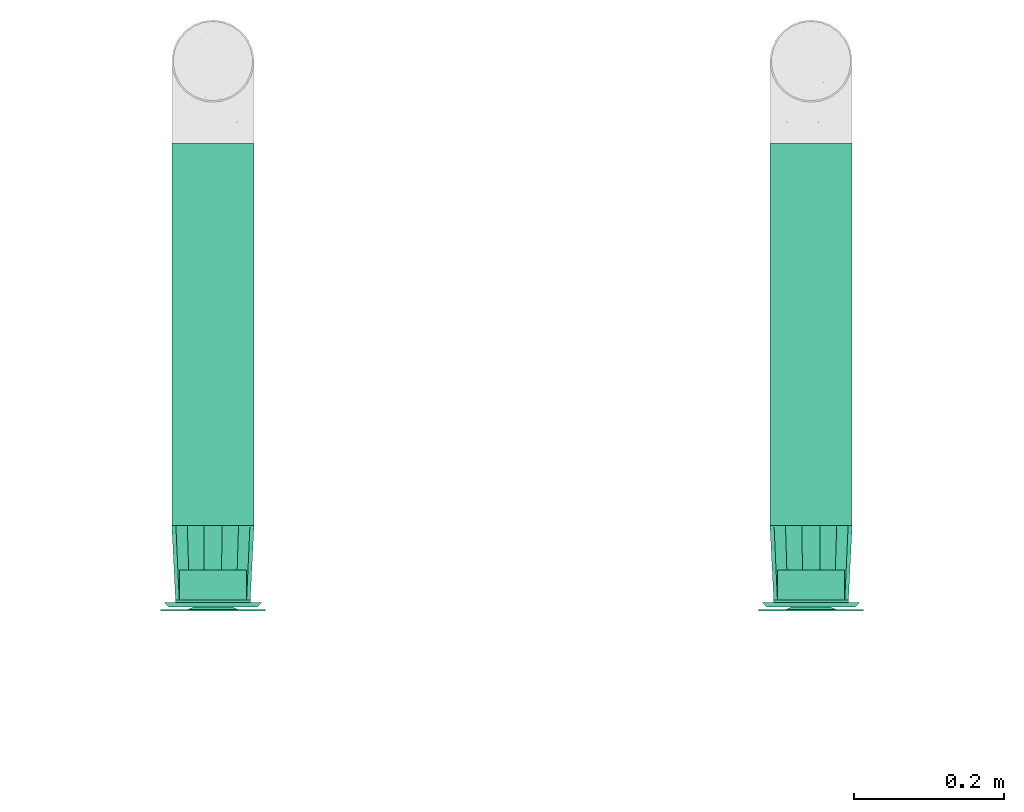
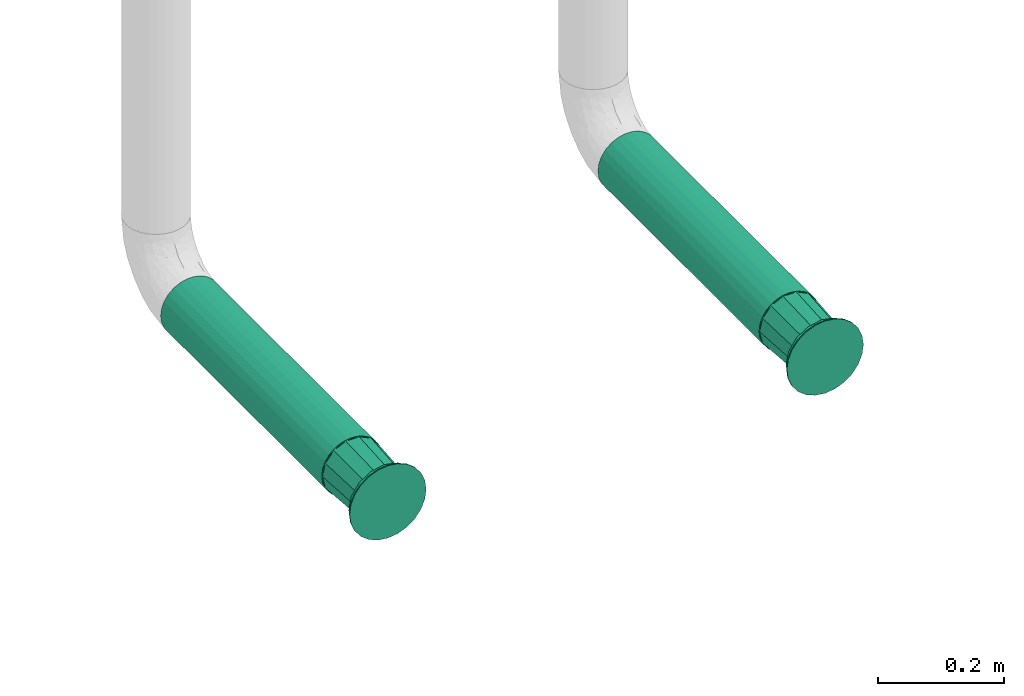
# One storey, part 54 of 115: 2 flow fittings, 2 flow segments, 2 flow terminals.
"""IFC2X3 building model written with IfcOpenShell, lengths in millimetres."""

from ifc_helpers import new_model, entity, si_unit, converted_unit, derived_unit, direction, frame, origin_with_axes, origin_2d_with_axis, place, context, subcontext, project, spatial, hollow_circle, extrude, open_shell, surface_model, source, transform, mapped, material, layer, layer_set, layer_usage, type_object, element, save


model = new_model("IFC2X3")

# Units and contexts
model_context = context("Model", 3, precision=1e-05, world=origin_with_axes(), true_north=direction((0.0, 1.0)))
body_context = subcontext(model_context, "Body", "Model", "MODEL_VIEW")
ifc_project = project(units=[si_unit("AREAUNIT", "SQUARE_METRE"), si_unit("VOLUMEUNIT", "CUBIC_METRE", prefix="DECI"), si_unit("TIMEUNIT", "SECOND"), si_unit("THERMODYNAMICTEMPERATUREUNIT", "DEGREE_CELSIUS"), si_unit("PRESSUREUNIT", "PASCAL"), si_unit("MASSUNIT", "GRAM", prefix="KILO"), si_unit("LENGTHUNIT", "METRE", prefix="MILLI"), si_unit("POWERUNIT", "WATT"), si_unit("ELECTRICCURRENTUNIT", "AMPERE"), si_unit("ELECTRICVOLTAGEUNIT", "VOLT"), derived_unit("VOLUMETRICFLOWRATEUNIT", [(si_unit("VOLUMEUNIT", "CUBIC_METRE", prefix="DECI"), 1), (si_unit("TIMEUNIT", "SECOND"), -1)]), derived_unit("LINEARVELOCITYUNIT", [(si_unit("LENGTHUNIT", "METRE"), 1), (si_unit("TIMEUNIT", "SECOND"), -1)]), derived_unit("MASSDENSITYUNIT", [(si_unit("MASSUNIT", "GRAM", prefix="KILO"), 1), (si_unit("VOLUMEUNIT", "CUBIC_METRE"), -1)]), converted_unit("PLANEANGLEUNIT", "DEGREE", entity("IfcRatioMeasure", 0.01745), si_unit("PLANEANGLEUNIT", "RADIAN"), dimensions=[0, 0, 0, 0, 0, 0, 0])], contexts=[model_context])

# Site, building, storey
site_placement = place(None, origin_with_axes())
site = spatial("IfcSite", under=ifc_project, at=site_placement, CompositionType="ELEMENT")
building_placement = place(site_placement, origin_with_axes())
building = spatial("IfcBuilding", under=site, at=building_placement, Name="mc-building", CompositionType="ELEMENT")
storey_placement = place(building_placement, frame((0.0, 0.0, 2950.0), z_axis=(0.0, 0.0, 1.0), x_axis=(1.0, 0.0, 0.0)))
storey = spatial("IfcBuildingStorey", under=building, at=storey_placement, Name="2. Korrus", CompositionType="ELEMENT", Elevation=2950.0)

# Flow terminals
air_terminal_type = type_object("IfcAirTerminalType", Name="100", PredefinedType="NOTDEFINED")
shared_shape_1 = source(origin_with_axes(), body_context, "Body", "SurfaceModel", [
    surface_model("IfcShellBasedSurfaceModel", [(11.2, 18.11733, -67.61481), (11.2, -18.11733, -67.61481), (11.2, 0.0, -70.0), (11.2, 67.61481, -18.11733), (11.2, 35.0, -60.62178), (11.2, 49.49747, -49.49747), (11.2, 60.62178, -35.0), (11.2, -67.61481, 18.11733), (11.2, -49.49747, -49.49747), (11.2, -67.61481, -18.11733), (11.2, -35.0, -60.62178), (11.2, -60.62178, -35.0), (11.2, -70.0, 0.0), (11.2, 18.11733, 67.61481), (11.2, 70.0, 0.0), (11.2, 67.61481, 18.11733), (11.2, 49.49747, 49.49747), (11.2, 60.62178, 35.0), (11.2, 35.0, 60.62178), (11.2, -49.49747, 49.49747), (11.2, -60.62178, 35.0), (11.2, -35.0, 60.62178), (11.2, -18.11733, 67.61481), (11.2, 0.0, 70.0), (9.2, 18.11733, 67.61481), (9.2, -67.61481, 18.11733), (9.2, 0.0, 70.0), (9.2, 49.49747, 49.49747), (9.2, 35.0, 60.62178), (9.2, 60.62178, 35.0), (9.2, 67.61481, 18.11733), (9.2, -35.0, 60.62178), (9.2, -49.49747, 49.49747), (9.2, -18.11733, 67.61481), (9.2, -60.62178, 35.0), (9.2, -67.61481, -18.11733), (9.2, -70.0, 0.0), (9.2, 67.61481, -18.11733), (9.2, 18.11733, -67.61481), (9.2, 49.49747, -49.49747), (9.2, 60.62178, -35.0), (9.2, 35.0, -60.62178), (9.2, -18.11733, -67.61481), (9.2, -49.49747, -49.49747), (9.2, -60.62178, -35.0), (9.2, -35.0, -60.62178), (9.2, 0.0, -70.0), (9.2, 70.0, 0.0), (9.2, 32.75, 0.0), (9.2, -16.375, 28.36233), (9.2, -28.36233, 16.375), (9.2, 16.375, 28.36233), (9.2, 0.0, 32.75), (9.2, 28.36233, 16.375), (9.2, -32.75, 0.0), (9.2, -16.375, -28.36233), (9.2, 16.375, -28.36233), (9.2, 0.0, -32.75), (9.2, 28.36233, -16.375), (9.2, -28.36233, -16.375), (6.2, -21.19625, -15.39997), (6.2, -21.19625, 15.39997), (6.2, 8.09625, 24.91768), (6.2, -8.09625, 24.91768), (6.2, -26.2, 0.0), (6.2, 21.19625, 15.39997), (6.2, -8.09625, -24.91768), (6.2, 21.19625, -15.39997), (6.2, 8.09625, -24.91768), (6.2, 26.2, 0.0), (9.2, 31.06579, -6.28555), (6.2, 23.69812, -7.69999), (6.2, -14.64625, -20.15883), (9.2, -22.36867, -22.36867), (6.2, -23.69812, -7.69999), (9.2, -31.06579, -6.28555), (6.2, 14.64625, -20.15883), (9.2, 8.1875, -30.55617), (6.2, 0.0, -24.91768), (9.2, 22.36867, -22.36867), (9.2, -8.1875, -30.55617), (9.2, -31.06579, 6.28555), (6.2, -23.69812, 7.69999), (6.2, 14.64625, 20.15883), (9.2, 22.36867, 22.36867), (6.2, 23.69812, 7.69999), (9.2, 31.06579, 6.28555), (6.2, -14.64625, 20.15883), (9.2, -8.1875, 30.55617), (6.2, 0.0, 24.91768), (9.2, -22.36867, 22.36867), (9.2, 8.1875, 30.55617), (6.2, -13.11761, 57.472), (6.2, -36.75472, 46.08897), (6.2, -53.11211, 25.57744), (6.2, 36.75472, 46.08897), (6.2, -58.95, 0.0), (6.2, 13.11761, 57.472), (6.2, 53.11211, 25.57744), (6.2, -53.11211, -25.57744), (6.2, -36.75472, -46.08897), (6.2, -13.11761, -57.472), (6.2, 58.95, 0.0), (6.2, 53.11211, -25.57744), (6.2, 13.11761, -57.472), (6.2, 36.75472, -46.08897), (0.0, -60.51411, 25.06576), (0.0, 0.0, 65.5), (0.0, 25.06576, 60.51411), (0.0, 46.3155, 46.3155), (0.0, 60.51411, 25.06576), (0.0, -46.3155, 46.3155), (0.0, -25.06576, 60.51411), (0.0, 0.0, -65.5), (0.0, -65.5, 0.0), (0.0, 65.5, 0.0), (0.0, 60.51411, -25.06576), (0.0, 46.3155, -46.3155), (0.0, 25.06576, -60.51411), (0.0, -46.3155, -46.3155), (0.0, -60.51411, -25.06576), (0.0, -25.06576, -60.51411), (6.2, 56.03105, -12.78872), (0.0, 53.4148, -35.69063), (0.0, 35.69063, -53.4148), (6.2, 24.93616, -51.78048), (0.0, -12.53288, -63.00706), (6.2, 0.0, -57.472), (0.0, -35.69063, -53.4148), (0.0, 63.00706, -12.53288), (6.2, 44.93342, -35.83321), (6.2, -24.93616, -51.78048), (6.2, -44.93342, -35.83321), (0.0, -53.4148, -35.69063), (0.0, 12.53288, -63.00706), (6.2, -56.03105, -12.78872), (0.0, -63.00706, -12.53288), (6.2, -56.03105, 12.78872), (0.0, -53.4148, 35.69063), (0.0, -35.69063, 53.4148), (6.2, -24.93616, 51.78048), (0.0, 12.53288, 63.00706), (6.2, 0.0, 57.472), (0.0, 35.69063, 53.4148), (0.0, -63.00706, 12.53288), (6.2, -44.93342, 35.83321), (6.2, 24.93616, 51.78048), (6.2, 44.93342, 35.83321), (0.0, 53.4148, 35.69063), (0.0, -12.53288, 63.00706), (6.2, 56.03105, 12.78872), (0.0, 63.00706, 12.53288), (-3.1, 12.94095, 48.29629), (-3.1, -35.35534, 35.35534), (-3.1, 0.0, 50.0), (-3.1, 35.35534, 35.35534), (-3.1, 25.0, 43.30127), (-3.1, -43.30127, 25.0), (-3.1, 43.30127, 25.0), (-3.1, -48.29629, -12.94095), (-3.1, -12.94095, 48.29629), (-3.1, -25.0, 43.30127), (-3.1, -50.0, 0.0), (-3.1, -48.29629, 12.94095), (-3.1, 48.29629, 12.94095), (-3.1, 12.94095, -48.29629), (-3.1, 50.0, 0.0), (-3.1, 48.29629, -12.94095), (-3.1, 35.35534, -35.35534), (-3.1, 43.30127, -25.0), (-3.1, 25.0, -43.30127), (-3.1, 0.0, -50.0), (-3.1, -35.35534, -35.35534), (-3.1, -43.30127, -25.0), (-3.1, -25.0, -43.30127), (-3.1, -12.94095, -48.29629), (0.0, 25.0, -43.30127), (0.0, 0.0, -50.0), (0.0, 12.94095, -48.29629), (0.0, 48.29629, -12.94095), (0.0, 35.35534, -35.35534), (0.0, -25.0, -43.30127), (0.0, 43.30127, -25.0), (0.0, -50.0, 0.0), (0.0, -12.94095, -48.29629), (0.0, -35.35534, -35.35534), (0.0, -48.29629, -12.94095), (0.0, -43.30127, -25.0), (0.0, 50.0, 0.0), (0.0, 43.30127, 25.0), (0.0, 12.94095, 48.29629), (0.0, 35.35534, 35.35534), (0.0, 25.0, 43.30127), (0.0, 0.0, 50.0), (0.0, -35.35534, 35.35534), (0.0, -43.30127, 25.0), (0.0, -48.29629, 12.94095), (0.0, -12.94095, 48.29629), (0.0, -25.0, 43.30127), (0.0, 48.29629, 12.94095), (-43.1, 0.0, 45.0), (-43.1, 11.64686, 43.46666), (-43.1, 22.5, 38.97115), (-43.1, -11.64686, 43.46666), (-43.1, 38.97115, 22.5), (-43.1, 43.46666, 11.64686), (-43.1, 31.81981, 31.81981), (-43.1, -22.5, 38.97115), (-43.1, -43.46666, 11.64686), (-43.1, -31.81981, 31.81981), (-43.1, -38.97115, 22.5), (-43.1, -45.0, 0.0), (-43.1, -43.46666, -11.64686), (-43.1, 45.0, 0.0), (-43.1, 43.46666, -11.64686), (-43.1, 38.97115, -22.5), (-43.1, 31.81981, -31.81981), (-43.1, 22.5, -38.97115), (-43.1, 11.64686, -43.46666), (-43.1, -31.81981, -31.81981), (-43.1, -38.97115, -22.5), (-43.1, -22.5, -38.97115), (-43.1, 0.0, -45.0), (-43.1, -11.64686, -43.46666), (-3.1, 22.5, -38.97115), (-3.1, 0.0, -45.0), (-3.1, 11.64686, -43.46666), (-3.1, 31.81981, -31.81981), (-3.1, -22.5, -38.97115), (-3.1, 38.97115, -22.5), (-3.1, 43.46666, -11.64686), (-3.1, 45.0, 0.0), (-3.1, -45.0, 0.0), (-3.1, -11.64686, -43.46666), (-3.1, -31.81981, -31.81981), (-3.1, -43.46666, -11.64686), (-3.1, -38.97115, -22.5), (-3.1, 0.0, 45.0), (-3.1, 43.46666, 11.64686), (-3.1, 38.97115, 22.5), (-3.1, 22.5, 38.97115), (-3.1, 31.81981, 31.81981), (-3.1, 11.64686, 43.46666), (-3.1, -11.64686, 43.46666), (-3.1, -43.46666, 11.64686), (-3.1, -31.81981, 31.81981), (-3.1, -38.97115, 22.5), (-3.1, -22.5, 38.97115)], [open_shell([[[0, 1, 2]], [[3, 0, 4]], [[5, 6, 3]], [[5, 3, 4]], [[7, 1, 0]], [[8, 7, 9]], [[10, 7, 8]], [[8, 9, 11]], [[12, 9, 7]], [[1, 7, 10]], [[7, 0, 3]], [[13, 14, 15]], [[16, 15, 17]], [[16, 18, 13]], [[16, 13, 15]], [[14, 13, 7]], [[7, 19, 20]], [[19, 7, 21]], [[7, 22, 21]], [[22, 7, 23]], [[7, 13, 23]], [[14, 7, 3]], [[24, 25, 26]], [[27, 24, 28]], [[27, 29, 30]], [[27, 30, 24]], [[25, 24, 30]], [[31, 25, 32]], [[25, 31, 33]], [[32, 25, 34]], [[33, 26, 25]], [[25, 35, 36]], [[25, 30, 37]], [[25, 37, 38]], [[39, 37, 40]], [[39, 41, 38]], [[39, 38, 37]], [[38, 42, 25]], [[35, 43, 44]], [[35, 25, 43]], [[45, 43, 25]], [[42, 45, 25]], [[38, 46, 42]], [[37, 30, 47]], [[35, 9, 36]], [[44, 11, 35]], [[10, 43, 45]], [[44, 43, 8]], [[1, 45, 42]], [[35, 11, 9]], [[9, 12, 36]], [[1, 10, 45]], [[8, 43, 10]], [[8, 11, 44]], [[2, 1, 42]], [[42, 46, 2]], [[38, 0, 46]], [[41, 4, 38]], [[6, 39, 40]], [[41, 39, 5]], [[3, 40, 37]], [[41, 5, 4]], [[4, 0, 38]], [[14, 3, 37]], [[6, 40, 3]], [[6, 5, 39]], [[47, 14, 37]], [[46, 0, 2]], [[30, 15, 47]], [[29, 17, 30]], [[18, 27, 28]], [[29, 27, 16]], [[13, 28, 24]], [[30, 17, 15]], [[15, 14, 47]], [[13, 18, 28]], [[16, 27, 18]], [[16, 17, 29]], [[23, 13, 24]], [[24, 26, 23]], [[33, 22, 26]], [[31, 21, 33]], [[20, 32, 34]], [[31, 32, 19]], [[7, 34, 25]], [[31, 19, 21]], [[21, 22, 33]], [[12, 7, 25]], [[20, 34, 7]], [[20, 19, 32]], [[36, 12, 25]], [[26, 22, 23]], [[48, 49, 50]], [[48, 51, 49]], [[49, 51, 52]], [[53, 51, 48]], [[48, 50, 54]], [[54, 55, 48]], [[56, 55, 57]], [[55, 58, 48]], [[58, 55, 56]], [[55, 54, 59]], [[60, 61, 62]], [[62, 61, 63]], [[64, 61, 60]], [[62, 65, 66]], [[67, 68, 65]], [[66, 60, 62]], [[65, 68, 66]], [[69, 67, 65]], [[69, 48, 70]], [[58, 71, 70]], [[72, 73, 60]], [[59, 74, 60]], [[75, 64, 74]], [[56, 68, 76]], [[72, 66, 55]], [[73, 72, 55]], [[68, 77, 78]], [[64, 75, 54]], [[59, 75, 74]], [[70, 71, 69]], [[67, 79, 76]], [[80, 55, 66]], [[68, 56, 77]], [[56, 76, 79]], [[79, 67, 58]], [[71, 58, 67]], [[80, 78, 57]], [[77, 57, 78]], [[66, 78, 80]], [[59, 60, 73]], [[64, 54, 81]], [[50, 82, 81]], [[83, 84, 65]], [[53, 85, 65]], [[86, 69, 85]], [[49, 63, 87]], [[83, 62, 51]], [[84, 83, 51]], [[63, 88, 89]], [[69, 86, 48]], [[53, 86, 85]], [[81, 82, 64]], [[61, 90, 87]], [[91, 51, 62]], [[63, 49, 88]], [[49, 87, 90]], [[90, 61, 50]], [[82, 50, 61]], [[91, 89, 52]], [[88, 52, 89]], [[62, 89, 91]], [[53, 65, 84]], [[92, 93, 94]], [[95, 94, 96]], [[97, 92, 95]], [[95, 92, 94]], [[96, 98, 95]], [[96, 99, 98]], [[99, 100, 101]], [[101, 102, 98]], [[102, 101, 103]], [[104, 105, 103]], [[101, 104, 103]], [[101, 98, 99]], [[106, 107, 108]], [[109, 110, 108]], [[106, 108, 110]], [[111, 112, 106]], [[106, 112, 107]], [[106, 113, 114]], [[106, 110, 113]], [[115, 116, 117]], [[117, 113, 110]], [[113, 117, 118]], [[114, 119, 120]], [[121, 119, 114]], [[121, 114, 113]], [[115, 117, 110]], [[103, 116, 122]], [[123, 116, 103]], [[124, 125, 118]], [[101, 126, 127]], [[100, 119, 128]], [[102, 122, 129]], [[103, 130, 123]], [[102, 129, 115]], [[113, 127, 126]], [[125, 124, 105]], [[130, 105, 117]], [[118, 125, 104]], [[124, 117, 105]], [[131, 100, 128]], [[119, 100, 132]], [[133, 99, 120]], [[134, 118, 104]], [[122, 116, 129]], [[127, 134, 104]], [[131, 121, 101]], [[99, 133, 132]], [[128, 121, 131]], [[130, 117, 123]], [[101, 121, 126]], [[99, 135, 120]], [[96, 136, 135]], [[136, 120, 135]], [[134, 127, 113]], [[133, 119, 132]], [[136, 96, 114]], [[94, 106, 137]], [[138, 106, 94]], [[139, 140, 112]], [[97, 141, 142]], [[95, 109, 143]], [[96, 137, 144]], [[94, 145, 138]], [[96, 144, 114]], [[107, 142, 141]], [[140, 139, 93]], [[145, 93, 111]], [[112, 140, 92]], [[139, 111, 93]], [[146, 95, 143]], [[109, 95, 147]], [[148, 98, 110]], [[149, 112, 92]], [[137, 106, 144]], [[142, 149, 92]], [[146, 108, 97]], [[98, 148, 147]], [[143, 108, 146]], [[145, 111, 138]], [[97, 108, 141]], [[98, 150, 110]], [[102, 151, 150]], [[151, 110, 150]], [[149, 142, 107]], [[148, 109, 147]], [[151, 102, 115]], [[152, 153, 154]], [[155, 152, 156]], [[157, 152, 158]], [[158, 152, 155]], [[158, 159, 157]], [[160, 153, 161]], [[160, 154, 153]], [[157, 162, 163]], [[153, 152, 157]], [[157, 159, 162]], [[158, 164, 159]], [[165, 166, 167]], [[168, 167, 169]], [[170, 165, 167]], [[170, 167, 168]], [[166, 165, 171]], [[159, 172, 173]], [[172, 159, 174]], [[174, 171, 175]], [[159, 164, 174]], [[166, 171, 174]], [[174, 164, 166]], [[176, 177, 178]], [[179, 176, 180]], [[176, 179, 181]], [[179, 180, 182]], [[179, 183, 181]], [[177, 181, 184]], [[177, 176, 181]], [[185, 186, 187]], [[186, 185, 181]], [[181, 183, 186]], [[183, 179, 188]], [[183, 188, 189]], [[190, 189, 191]], [[189, 190, 183]], [[190, 191, 192]], [[193, 194, 190]], [[183, 195, 196]], [[183, 190, 195]], [[194, 197, 198]], [[194, 195, 190]], [[197, 194, 193]], [[189, 188, 199]], [[164, 199, 166]], [[158, 189, 164]], [[192, 155, 156]], [[158, 155, 191]], [[190, 156, 152]], [[164, 189, 199]], [[199, 188, 166]], [[190, 192, 156]], [[191, 155, 192]], [[191, 189, 158]], [[193, 190, 152]], [[152, 154, 193]], [[160, 197, 154]], [[161, 198, 160]], [[195, 153, 157]], [[161, 153, 194]], [[196, 157, 163]], [[161, 194, 198]], [[198, 197, 160]], [[183, 196, 163]], [[195, 157, 196]], [[195, 194, 153]], [[162, 183, 163]], [[154, 197, 193]], [[159, 186, 162]], [[173, 187, 159]], [[181, 172, 174]], [[173, 172, 185]], [[184, 174, 175]], [[159, 187, 186]], [[186, 183, 162]], [[184, 181, 174]], [[185, 172, 181]], [[185, 187, 173]], [[177, 184, 175]], [[175, 171, 177]], [[165, 178, 171]], [[170, 176, 165]], [[182, 168, 169]], [[170, 168, 180]], [[179, 169, 167]], [[170, 180, 176]], [[176, 178, 165]], [[188, 179, 167]], [[182, 169, 179]], [[182, 180, 168]], [[166, 188, 167]], [[171, 178, 177]], [[200, 201, 202]], [[203, 200, 202]], [[204, 205, 202]], [[204, 202, 206]], [[203, 202, 205]], [[207, 208, 209]], [[207, 203, 205]], [[209, 208, 210]], [[211, 208, 212]], [[208, 207, 212]], [[207, 205, 212]], [[213, 214, 215]], [[205, 215, 212]], [[212, 216, 217]], [[216, 212, 215]], [[218, 219, 217]], [[212, 219, 220]], [[212, 217, 219]], [[221, 222, 223]], [[222, 221, 219]], [[218, 222, 219]], [[215, 205, 213]], [[224, 225, 226]], [[227, 228, 224]], [[229, 230, 231]], [[228, 227, 229]], [[229, 232, 228]], [[225, 228, 233]], [[225, 224, 228]], [[234, 235, 236]], [[235, 234, 228]], [[228, 232, 235]], [[232, 229, 231]], [[237, 238, 239]], [[240, 239, 241]], [[240, 242, 237]], [[240, 237, 239]], [[238, 237, 243]], [[244, 245, 246]], [[247, 244, 232]], [[244, 247, 245]], [[232, 238, 247]], [[238, 243, 247]], [[238, 232, 231]], [[205, 238, 213]], [[204, 239, 205]], [[240, 206, 202]], [[204, 206, 241]], [[242, 202, 201]], [[205, 239, 238]], [[238, 231, 213]], [[240, 202, 242]], [[241, 206, 240]], [[241, 239, 204]], [[201, 237, 242]], [[201, 200, 237]], [[243, 203, 207]], [[209, 247, 207]], [[246, 210, 208]], [[209, 210, 245]], [[244, 208, 211]], [[203, 243, 200]], [[207, 247, 243]], [[200, 243, 237]], [[209, 245, 247]], [[210, 246, 245]], [[244, 246, 208]], [[211, 232, 244]], [[212, 235, 211]], [[220, 236, 212]], [[228, 219, 221]], [[220, 219, 234]], [[233, 221, 223]], [[212, 236, 235]], [[235, 232, 211]], [[233, 228, 221]], [[234, 219, 228]], [[234, 236, 220]], [[225, 233, 223]], [[223, 222, 225]], [[226, 218, 217]], [[216, 224, 217]], [[229, 215, 214]], [[216, 215, 227]], [[230, 214, 213]], [[218, 226, 222]], [[217, 224, 226]], [[222, 226, 225]], [[216, 227, 224]], [[215, 229, 227]], [[230, 229, 214]], [[213, 231, 230]]])]),
])
for number, where, z_axis, x_axis, name in (
    (1, (15757.14677, 12939.66532, 2300.0), (0.0, 0.0, 1.0), (0.0, -1.0, 0.0), "100"),
    (2, (14957.14677, 12939.66532, 2300.0), (0.0, 0.0, 1.0), (0.0, -1.0, 0.0), "100"),
):
    element("IfcFlowTerminal", number, at=place(storey_placement, frame(where, z_axis=z_axis, x_axis=x_axis)), inside=storey, type_object=air_terminal_type, Name=name, context=body_context, shape_type="MappedRepresentation", body=[
        mapped(shared_shape_1, transform((0.0, 0.0, 0.0), scale=1.0)),
    ])

# Flow segments
ifc_material = material(Name="FZ1")
ifc_layer = layer(ifc_material, 0.0)
ifc_layer_set = layer_set([ifc_layer], Name="FZ1")
ifc_layer_usage = layer_usage(ifc_layer_set, "AXIS1", "POSITIVE", 0.0)
duct_segment_type = type_object("IfcDuctSegmentType", PredefinedType="RIGIDSEGMENT")
shared_shape_2 = source(origin_with_axes(), body_context, "Body", "SweptSolid", [
    extrude(hollow_circle(Radius=55.0, WallThickness=2.0, at=origin_2d_with_axis()), frame((0.0, 0.0, 0.0), z_axis=(1.0, 0.0, 0.0), x_axis=(0.0, 1.0, 0.0)), (0.0, 0.0, 1.0), 510.8),
])
for number, where, z_axis, x_axis in (
    (3, (15757.14677, 13042.76532, 2300.0), (0.0, 0.0, 1.0), (0.0, 1.0, 0.0)),
    (4, (14957.14677, 13042.76532, 2300.0), (0.0, 0.0, 1.0), (0.0, 1.0, 0.0)),
):
    element("IfcFlowSegment", number, at=place(storey_placement, frame(where, z_axis=z_axis, x_axis=x_axis)), inside=storey, type_object=duct_segment_type, material=ifc_layer_usage, context=body_context, shape_type="MappedRepresentation", body=[
        mapped(shared_shape_2, transform((0.0, 0.0, 0.0), scale=1.0)),
    ])

# Flow fittings
duct_fitting_type = type_object("IfcDuctFittingType", PredefinedType="TRANSITION")
shared_shape_3 = source(origin_with_axes(), body_context, "Body", "SurfaceModel", [
    surface_model("IfcShellBasedSurfaceModel", [(0.0, 12.94095, 48.29629), (0.0, -35.35534, 35.35534), (0.0, 0.0, 50.0), (0.0, 35.35534, 35.35534), (0.0, 25.0, 43.30127), (0.0, 43.30127, 25.0), (0.0, 48.29629, 12.94095), (0.0, -12.94095, 48.29629), (0.0, -25.0, 43.30127), (0.0, -48.29629, 12.94095), (0.0, -43.30127, 25.0), (0.0, -25.0, -43.30127), (0.0, -48.29629, -12.94095), (0.0, -50.0, 0.0), (0.0, 48.29629, -12.94095), (0.0, 12.94095, -48.29629), (0.0, 43.30127, -25.0), (0.0, 35.35534, -35.35534), (0.0, 25.0, -43.30127), (0.0, -35.35534, -35.35534), (0.0, -43.30127, -25.0), (0.0, -12.94095, -48.29629), (0.0, 0.0, -50.0), (0.0, 50.0, 0.0), (100.0, -55.0, 0.0), (100.0, -12.23865, 53.62104), (100.0, -34.29194, 43.00073), (100.0, 49.55329, -23.86361), (100.0, 12.23865, 53.62104), (100.0, 34.29194, 43.00073), (100.0, 55.0, 0.0), (100.0, 49.55329, 23.86361), (100.0, -49.55329, 23.86361), (100.0, 12.23865, -53.62104), (100.0, -49.55329, -23.86361), (100.0, -34.29194, -43.00073), (100.0, 34.29194, -43.00073), (100.0, -12.23865, -53.62104), (0.0, 11.12605, 48.7464), (0.0, -11.12605, 48.7464), (0.0, 31.17449, 39.09157), (0.0, -45.04844, -21.69419), (0.0, -45.04844, 21.69419), (0.0, -31.17449, 39.09157), (0.0, 45.04844, 21.69419), (0.0, 45.04844, -21.69419), (0.0, 31.17449, -39.09157), (0.0, -31.17449, -39.09157), (0.0, -11.12605, -48.7464), (0.0, 11.12605, -48.7464), (0.0, -47.52422, -10.84709), (100.0, -41.92261, -33.43217), (0.0, -38.11147, -30.39288), (100.0, 41.92261, -33.43217), (0.0, 38.11147, -30.39288), (0.0, -21.15027, -43.91899), (100.0, -23.2653, -48.31088), (100.0, -52.32388, -11.72483), (100.0, 0.0, -53.62104), (0.0, 0.0, -48.7464), (100.0, 23.2653, -48.31088), (0.0, 21.15027, -43.91899), (100.0, 52.32388, -11.72483), (0.0, 47.52422, -10.84709), (0.0, 47.52422, 10.84709), (100.0, 41.92261, 33.43217), (0.0, 38.11147, 30.39288), (100.0, -41.92261, 33.43217), (0.0, -38.11147, 30.39288), (0.0, 21.15027, 43.91899), (100.0, 23.2653, 48.31088), (100.0, 52.32388, 11.72483), (100.0, 0.0, 53.62104), (0.0, 0.0, 48.7464), (100.0, -23.2653, 48.31088), (0.0, -21.15027, 43.91899), (100.0, -52.32388, 11.72483), (0.0, -47.52422, 10.84709), (100.0, 27.5, -47.63139), (100.0, 0.0, -55.0), (100.0, 14.23505, -53.12592), (100.0, 38.89087, -38.89087), (100.0, -27.5, -47.63139), (100.0, 47.63139, -27.5), (100.0, 53.12592, -14.23505), (100.0, -14.23505, -53.12592), (100.0, -47.63139, -27.5), (100.0, -38.89087, -38.89087), (100.0, -53.12592, -14.23505), (100.0, 53.12592, 14.23505), (100.0, 47.63139, 27.5), (100.0, 27.5, 47.63139), (100.0, 38.89087, 38.89087), (100.0, 14.23505, 53.12592), (100.0, 0.0, 55.0), (100.0, -47.63139, 27.5), (100.0, -53.12592, 14.23505), (100.0, -27.5, 47.63139), (100.0, -38.89087, 38.89087), (100.0, -14.23505, 53.12592), (98.0, 0.0, 55.0), (98.0, 14.23505, 53.12592), (98.0, 27.5, 47.63139), (98.0, 38.89087, 38.89087), (98.0, 47.63139, 27.5), (98.0, -47.63139, 27.5), (98.0, 53.12592, -14.23505), (98.0, -27.5, 47.63139), (98.0, -14.23505, 53.12592), (98.0, -38.89087, 38.89087), (98.0, -55.0, 0.0), (98.0, -53.12592, 14.23505), (98.0, 53.12592, 14.23505), (98.0, 47.63139, -27.5), (98.0, -27.5, -47.63139), (98.0, 0.0, -55.0), (98.0, 38.89087, -38.89087), (98.0, 27.5, -47.63139), (98.0, 14.23505, -53.12592), (98.0, -47.63139, -27.5), (98.0, -38.89087, -38.89087), (98.0, -53.12592, -14.23505), (98.0, -14.23505, -53.12592), (98.0, 55.0, 0.0), (2.0, 12.94095, -48.29629), (2.0, 25.0, -43.30127), (2.0, 35.35534, -35.35534), (2.0, 43.30127, -25.0), (2.0, 48.29629, -12.94095), (2.0, 0.0, -50.0), (2.0, 50.0, 0.0), (2.0, -25.0, -43.30127), (2.0, -12.94095, -48.29629), (2.0, -35.35534, -35.35534), (2.0, -48.29629, -12.94095), (2.0, -43.30127, -25.0), (2.0, -48.29629, 12.94095), (2.0, 48.29629, 12.94095), (2.0, 43.30127, 25.0), (2.0, 35.35534, 35.35534), (2.0, -35.35534, 35.35534), (2.0, 12.94095, 48.29629), (2.0, 25.0, 43.30127), (2.0, 0.0, 50.0), (2.0, -43.30127, 25.0), (2.0, -50.0, 0.0), (2.0, -12.94095, 48.29629), (2.0, -25.0, 43.30127)], [open_shell([[[0, 1, 2]], [[3, 0, 4]], [[3, 5, 6]], [[0, 3, 1]], [[6, 1, 3]], [[7, 1, 8]], [[7, 2, 1]], [[1, 9, 10]], [[9, 1, 11]], [[12, 13, 9]], [[11, 1, 6]], [[6, 14, 11]], [[15, 14, 16]], [[17, 18, 15]], [[17, 15, 16]], [[11, 14, 15]], [[12, 19, 20]], [[19, 12, 11]], [[15, 21, 11]], [[12, 9, 11]], [[22, 21, 15]], [[14, 6, 23]], [[24, 25, 26]], [[25, 27, 28]], [[29, 28, 27]], [[27, 30, 31]], [[31, 29, 27]], [[24, 26, 32]], [[33, 24, 34]], [[33, 34, 35]], [[36, 27, 33]], [[33, 27, 24]], [[35, 37, 33]], [[24, 27, 25]], [[38, 23, 39]], [[40, 23, 38]], [[41, 42, 43]], [[41, 13, 42]], [[23, 43, 39]], [[40, 44, 23]], [[41, 23, 45]], [[41, 45, 46]], [[47, 41, 48]], [[49, 48, 41]], [[41, 46, 49]], [[23, 41, 43]], [[34, 50, 41]], [[47, 51, 52]], [[45, 27, 53]], [[36, 54, 53]], [[55, 48, 56]], [[34, 57, 50]], [[57, 13, 50]], [[13, 57, 24]], [[55, 35, 47]], [[35, 51, 47]], [[51, 41, 52]], [[58, 59, 49]], [[60, 61, 46]], [[37, 59, 58]], [[62, 63, 23]], [[35, 55, 56]], [[23, 30, 62]], [[53, 54, 45]], [[48, 37, 56]], [[33, 49, 61]], [[49, 33, 58]], [[54, 36, 46]], [[63, 27, 45]], [[34, 41, 51]], [[33, 61, 60]], [[48, 59, 37]], [[27, 63, 62]], [[46, 36, 60]], [[31, 64, 44]], [[40, 65, 66]], [[42, 32, 67]], [[26, 68, 67]], [[69, 38, 70]], [[31, 71, 64]], [[71, 23, 64]], [[23, 71, 30]], [[69, 29, 40]], [[29, 65, 40]], [[65, 44, 66]], [[72, 73, 39]], [[74, 75, 43]], [[28, 73, 72]], [[76, 77, 13]], [[29, 69, 70]], [[13, 24, 76]], [[67, 68, 42]], [[38, 28, 70]], [[25, 39, 75]], [[39, 25, 72]], [[68, 26, 43]], [[77, 32, 42]], [[31, 44, 65]], [[25, 75, 74]], [[38, 73, 28]], [[32, 77, 76]], [[43, 26, 74]], [[78, 79, 80]], [[81, 82, 78]], [[82, 83, 84]], [[81, 83, 82]], [[30, 82, 84]], [[79, 82, 85]], [[79, 78, 82]], [[82, 86, 87]], [[82, 30, 86]], [[24, 88, 86]], [[86, 30, 89]], [[90, 24, 89]], [[91, 90, 92]], [[91, 93, 94]], [[90, 91, 24]], [[94, 95, 91]], [[24, 95, 96]], [[24, 91, 95]], [[94, 97, 98]], [[98, 95, 94]], [[97, 94, 99]], [[89, 24, 86]], [[100, 101, 102]], [[100, 102, 103]], [[100, 104, 105]], [[104, 100, 103]], [[106, 105, 104]], [[100, 107, 108]], [[100, 109, 107]], [[105, 110, 111]], [[109, 100, 105]], [[105, 106, 110]], [[106, 104, 112]], [[106, 113, 110]], [[113, 114, 110]], [[115, 116, 117]], [[113, 116, 115]], [[117, 118, 115]], [[119, 114, 120]], [[121, 110, 119]], [[114, 115, 122]], [[119, 110, 114]], [[115, 114, 113]], [[123, 106, 112]], [[121, 88, 110]], [[119, 86, 121]], [[82, 120, 114]], [[119, 120, 87]], [[85, 114, 122]], [[121, 86, 88]], [[88, 24, 110]], [[85, 82, 114]], [[87, 120, 82]], [[87, 86, 119]], [[79, 85, 122]], [[122, 115, 79]], [[118, 80, 115]], [[117, 78, 118]], [[83, 116, 113]], [[117, 116, 81]], [[84, 113, 106]], [[117, 81, 78]], [[78, 80, 118]], [[30, 84, 106]], [[83, 113, 84]], [[83, 81, 116]], [[123, 30, 106]], [[115, 80, 79]], [[112, 89, 123]], [[104, 90, 112]], [[91, 103, 102]], [[104, 103, 92]], [[93, 102, 101]], [[112, 90, 89]], [[89, 30, 123]], [[93, 91, 102]], [[92, 103, 91]], [[92, 90, 104]], [[94, 93, 101]], [[101, 100, 94]], [[108, 99, 100]], [[107, 97, 108]], [[95, 109, 105]], [[107, 109, 98]], [[96, 105, 111]], [[107, 98, 97]], [[97, 99, 108]], [[24, 96, 111]], [[95, 105, 96]], [[95, 98, 109]], [[110, 24, 111]], [[100, 99, 94]], [[124, 125, 126]], [[124, 126, 127]], [[124, 128, 129]], [[128, 124, 127]], [[129, 128, 130]], [[129, 131, 132]], [[129, 130, 131]], [[133, 134, 135]], [[134, 133, 131]], [[131, 136, 134]], [[131, 130, 137]], [[137, 138, 139]], [[140, 137, 139]], [[140, 139, 141]], [[141, 139, 142]], [[140, 141, 143]], [[136, 140, 144]], [[145, 134, 136]], [[140, 146, 147]], [[131, 140, 136]], [[143, 146, 140]], [[131, 137, 140]], [[12, 134, 13]], [[20, 135, 12]], [[131, 19, 11]], [[20, 19, 133]], [[132, 11, 21]], [[12, 135, 134]], [[134, 145, 13]], [[132, 131, 11]], [[133, 19, 131]], [[133, 135, 20]], [[129, 132, 21]], [[21, 22, 129]], [[15, 124, 22]], [[18, 125, 15]], [[127, 17, 16]], [[18, 17, 126]], [[128, 16, 14]], [[18, 126, 125]], [[125, 124, 15]], [[130, 128, 14]], [[127, 16, 128]], [[127, 126, 17]], [[23, 130, 14]], [[22, 124, 129]], [[6, 137, 23]], [[5, 138, 6]], [[142, 3, 4]], [[5, 3, 139]], [[141, 4, 0]], [[6, 138, 137]], [[137, 130, 23]], [[141, 142, 4]], [[139, 3, 142]], [[139, 138, 5]], [[143, 141, 0]], [[0, 2, 143]], [[7, 146, 2]], [[8, 147, 7]], [[144, 1, 10]], [[8, 1, 140]], [[136, 10, 9]], [[8, 140, 147]], [[147, 146, 7]], [[145, 136, 9]], [[144, 10, 136]], [[144, 140, 1]], [[13, 145, 9]], [[2, 146, 143]]])]),
])
for number, where, z_axis, x_axis in (
    (5, (15757.14677, 12942.76532, 2300.0), (0.0, 0.0, 1.0), (0.0, 1.0, 0.0)),
    (6, (14957.14677, 12942.76532, 2300.0), (0.0, 0.0, 1.0), (0.0, 1.0, 0.0)),
):
    element("IfcFlowFitting", number, at=place(storey_placement, frame(where, z_axis=z_axis, x_axis=x_axis)), inside=storey, type_object=duct_fitting_type, context=body_context, shape_type="MappedRepresentation", body=[
        mapped(shared_shape_3, transform((0.0, 0.0, 0.0), scale=1.0)),
    ])

save(model, "model.ifc")
